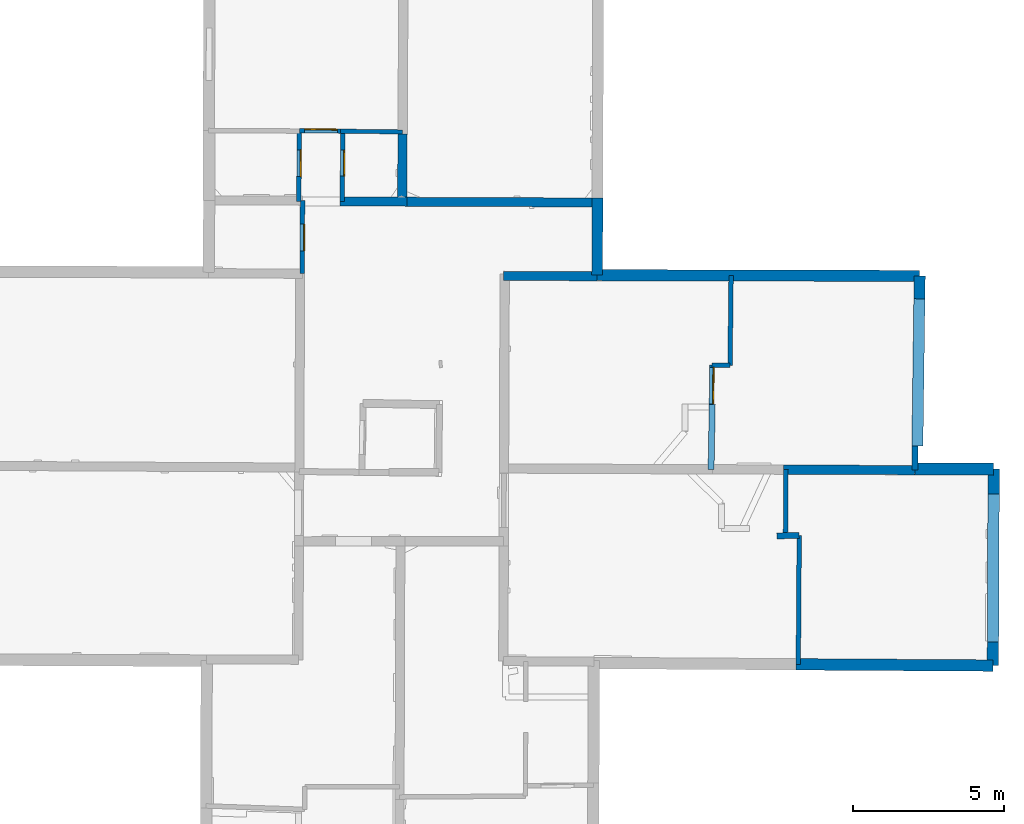
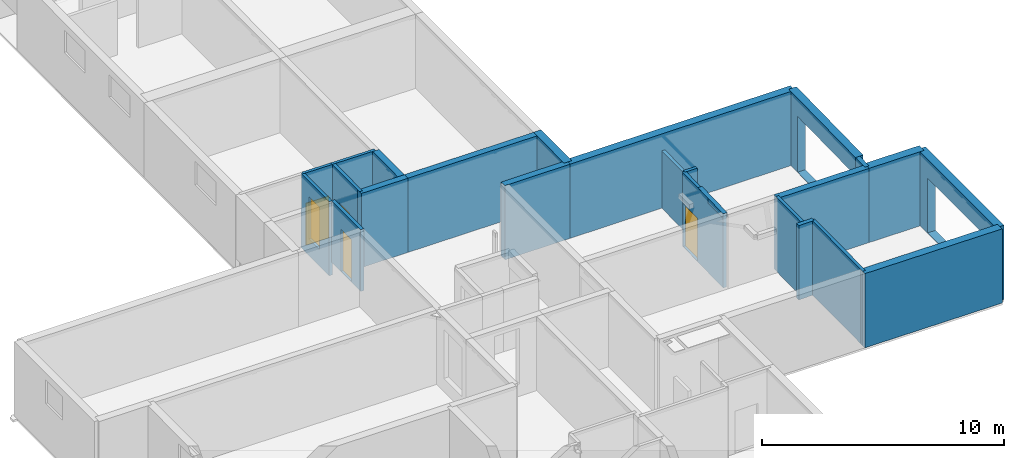
# One storey, part 4 of 12: 24 walls, 5 doors, 7 openings.
"""IFC2X3 building model written with IfcOpenShell, lengths in metres."""

from ifc_helpers import new_model, entity, si_unit, converted_unit, derived_unit, direction, frame, frame_2d, origin, origin_2d_with_axis, place, context, subcontext, project, spatial, polyline, rectangle, outline, extrude, source, transform, mapped, material, layer, layer_set, layer_usage, type_object, type_shapes, element, fill, save


model = new_model("IFC2X3")

# Units and contexts
model_context = context("Model", 3, precision=1e-05, world=origin(), true_north=direction((0.0, 1.0)))
body_context = subcontext(model_context, "Body", "Model", "MODEL_VIEW")
ifc_project = project(units=[si_unit("LENGTHUNIT", "METRE"), si_unit("AREAUNIT", "SQUARE_METRE"), si_unit("VOLUMEUNIT", "CUBIC_METRE"), converted_unit("PLANEANGLEUNIT", "DEGREE", entity("IfcRatioMeasure", 0.0174532925199433), si_unit("PLANEANGLEUNIT", "RADIAN"), dimensions=[0, 0, 0, 0, 0, 0, 0]), si_unit("MASSUNIT", "GRAM", prefix="KILO"), derived_unit("MASSDENSITYUNIT", [(si_unit("MASSUNIT", "GRAM", prefix="KILO"), 1), (si_unit("LENGTHUNIT", "METRE"), -3)]), derived_unit("MOMENTOFINERTIAUNIT", [(si_unit("LENGTHUNIT", "METRE"), 4)]), si_unit("TIMEUNIT", "SECOND"), si_unit("FREQUENCYUNIT", "HERTZ"), si_unit("THERMODYNAMICTEMPERATUREUNIT", "DEGREE_CELSIUS"), derived_unit("THERMALTRANSMITTANCEUNIT", [(si_unit("MASSUNIT", "GRAM", prefix="KILO"), 1), (si_unit("THERMODYNAMICTEMPERATUREUNIT", "KELVIN"), -1), (si_unit("TIMEUNIT", "SECOND"), -3)]), derived_unit("VOLUMETRICFLOWRATEUNIT", [(si_unit("LENGTHUNIT", "METRE"), 3), (si_unit("TIMEUNIT", "SECOND"), -1)]), si_unit("ELECTRICCURRENTUNIT", "AMPERE"), si_unit("ELECTRICVOLTAGEUNIT", "VOLT"), si_unit("POWERUNIT", "WATT"), si_unit("FORCEUNIT", "NEWTON", prefix="KILO"), si_unit("ILLUMINANCEUNIT", "LUX"), si_unit("LUMINOUSFLUXUNIT", "LUMEN"), si_unit("LUMINOUSINTENSITYUNIT", "CANDELA"), derived_unit("USERDEFINED", [(si_unit("MASSUNIT", "GRAM", prefix="KILO"), -1), (si_unit("LENGTHUNIT", "METRE"), -2), (si_unit("TIMEUNIT", "SECOND"), 3), (si_unit("LUMINOUSFLUXUNIT", "LUMEN"), 1)]), derived_unit("LINEARVELOCITYUNIT", [(si_unit("LENGTHUNIT", "METRE"), 1), (si_unit("TIMEUNIT", "SECOND"), -1)]), si_unit("PRESSUREUNIT", "PASCAL"), derived_unit("USERDEFINED", [(si_unit("LENGTHUNIT", "METRE"), -2), (si_unit("MASSUNIT", "GRAM", prefix="KILO"), 1), (si_unit("TIMEUNIT", "SECOND"), -2)]), derived_unit("LINEARFORCEUNIT", [(si_unit("MASSUNIT", "GRAM", prefix="KILO"), 1), (si_unit("LENGTHUNIT", "METRE"), 1), (si_unit("TIMEUNIT", "SECOND"), -2), (si_unit("LENGTHUNIT", "METRE"), -1)]), derived_unit("PLANARFORCEUNIT", [(si_unit("MASSUNIT", "GRAM", prefix="KILO"), 1), (si_unit("LENGTHUNIT", "METRE"), 1), (si_unit("TIMEUNIT", "SECOND"), -2), (si_unit("LENGTHUNIT", "METRE"), -2)])], contexts=[model_context])

# Site, building, storey
placement_1 = place(None, origin())
site = spatial("IfcSite", under=ifc_project, at=placement_1, CompositionType="ELEMENT")
building = spatial("IfcBuilding", under=site, at=placement_1, CompositionType="ELEMENT")
storey_placement = place(placement_1, frame((0.0, 0.0, -1.46125340461731)))
storey = spatial("IfcBuildingStorey", under=building, at=storey_placement, Name="Level 1", CompositionType="ELEMENT", Elevation=-1.46125340461731)

# Walls
ifc_material_1 = material(Name="Default wall")
ifc_layer_1 = layer(ifc_material_1, 0.2)
ifc_layer_set_1 = layer_set([ifc_layer_1], Name="wall_thickness_0.2000")
ifc_layer_usage_1 = layer_usage(ifc_layer_set_1, "AXIS2", "POSITIVE", -0.1)
wall_type_1 = type_object("IfcWallType", Name="wall_thickness_0.2000", PredefinedType="STANDARD", material=ifc_layer_set_1)
wall_1_placement = place(storey_placement, frame((18.6490779756454, 17.1740591295376, 0.0), z_axis=(0.0, 0.0, 1.0), x_axis=(0.999891502829233, 0.0147303282345586, 0.0)))
element("IfcWallStandardCase", 1, at=wall_1_placement, inside=storey, type_object=wall_type_1, material=ifc_layer_usage_1, Name="Wall:608", ObjectType="Wall", context=body_context, shape_type="SweptSolid", body=[
    extrude(outline(polyline([(0.744276690025487, -0.1), (0.744276690025487, 0.1), (0.0, 0.1), (0.0, -0.1), (0.744276690025487, -0.1)])), origin(), (0.0, 0.0, 1.0), 3.74198617935181),
])
wall_2_placement = place(storey_placement, frame((23.2358447544177, 20.1531341213829, 0.0), z_axis=(0.0, 0.0, 1.0), x_axis=(-0.0126945433330581, -0.999919421038298, 0.0)))
element("IfcWallStandardCase", 2, at=wall_2_placement, inside=storey, type_object=wall_type_1, material=ifc_layer_usage_1, Name="Wall:653", ObjectType="Wall", context=body_context, shape_type="SweptSolid", body=[
    extrude(outline(polyline([(0.799928272697267, -0.1), (0.799928272697267, 0.1), (0.0, 0.1), (0.0, -0.1), (0.799928272697267, -0.1)])), origin(), (0.0, 0.0, 1.0), 3.74198617935181),
])
placement_2 = place(placement_1, frame((0.0, 0.0, 2.04199981689453)))
wall_3_placement = place(placement_2, frame((16.4694131691114, 19.3806354082784, 0.0), z_axis=(0.0, 0.0, 1.0), x_axis=(0.0179968916085182, 0.999838042831153, 0.0)))
element("IfcWallStandardCase", 3, at=wall_3_placement, inside=storey, type_object=wall_type_1, material=ifc_layer_usage_1, Name="Wall:681", ObjectType="Wall", context=body_context, shape_type="SweptSolid", body=[
    extrude(outline(polyline([(2.15260273405872, -0.1), (2.15260273405872, 0.1), (0.0, 0.1), (0.0, -0.1), (2.15260273405872, -0.1)])), origin(), (0.0, 0.0, 1.0), 0.238732957839966),
])
ifc_layer_2 = layer(ifc_material_1, 0.379999995231628)
ifc_layer_set_2 = layer_set([ifc_layer_2], Name="wall_thickness_0.3800")
ifc_layer_usage_2 = layer_usage(ifc_layer_set_2, "AXIS2", "POSITIVE", -0.189999997615814)
wall_type_2 = type_object("IfcWallType", Name="wall_thickness_0.3800", PredefinedType="STANDARD", material=ifc_layer_set_2)
wall_4_placement = place(storey_placement, frame((19.2877350168227, 12.911915257359, 0.0), z_axis=(0.0, 0.0, 1.0), x_axis=(0.999979999783227, -0.00632455797173892, 0.0)))
element("IfcWallStandardCase", 4, at=wall_4_placement, inside=storey, type_object=wall_type_2, material=ifc_layer_usage_2, Name="Wall:521", ObjectType="Wall", context=body_context, shape_type="SweptSolid", body=[
    extrude(outline(polyline([(6.53007216169667, -0.189999997615814), (6.53007216169667, 0.189999997615814), (0.0, 0.189999997615814), (0.0, -0.189999997615814), (6.53007216169667, -0.189999997615814)])), origin(), (0.0, 0.0, 1.0), 3.74198617935181),
])

# Wall, opening
wall_5_placement = place(storey_placement, frame((25.8438703285536, 19.3839390076992, 0.0), z_axis=(0.0, 0.0, 1.0), x_axis=(-0.00402180381335679, -0.99999191251434, 0.0)))
wall_5 = element("IfcWallStandardCase", 5, at=wall_5_placement, inside=storey, type_object=wall_type_2, material=ifc_layer_usage_2, Name="Wall:671", ObjectType="Wall", context=body_context, shape_type="SweptSolid", body=[
    extrude(outline(polyline([(6.51337741439527, -0.189999997615814), (6.51337741439527, 0.189999997615814), (0.0, 0.189999997615814), (0.0, -0.189999997615814), (6.51337741439527, -0.189999997615814)])), origin(), (0.0, 0.0, 1.0), 3.74198617935181),
])
opening_1_placement = place(wall_5_placement, frame((0.823121023784291, -0.189999997615814, 0.0262539386749268)))
element("IfcOpeningElement", 6, at=opening_1_placement, cuts=wall_5, Name="Opening : 4905 x 2750 : 429", ObjectType="Opening", context=body_context, shape_type="SweptSolid", body=[
    extrude(rectangle(XDim=4.905, YDim=2.75, at=frame_2d((1.375, 2.4525), x_axis=(0.0, 1.0))), frame((0.0, 0.0, 0.0), z_axis=(0.0, 1.0, 0.0), x_axis=(0.0, 0.0, 1.0)), (0.0, 0.0, 1.0), 0.379999995231628),
])

# Wall
ifc_layer_3 = layer(ifc_material_1, 0.370000004768372)
ifc_layer_set_3 = layer_set([ifc_layer_3], Name="wall_thickness_0.3700")
ifc_layer_usage_3 = layer_usage(ifc_layer_set_3, "AXIS2", "POSITIVE", -0.185000002384186)
wall_type_3 = type_object("IfcWallType", Name="wall_thickness_0.3700", PredefinedType="STANDARD", material=ifc_layer_set_3)
wall_6_placement = place(storey_placement, frame((12.6910763943773, 25.8209457186515, 0.0), z_axis=(0.0, 0.0, 1.0), x_axis=(0.999997215283087, -0.00235996315037195, 0.0)))
element("IfcWallStandardCase", 7, at=wall_6_placement, inside=storey, type_object=wall_type_3, material=ifc_layer_usage_3, Name="Wall:637", ObjectType="Wall", context=body_context, shape_type="SweptSolid", body=[
    extrude(outline(polyline([(10.6990997707707, -0.185000002384186), (10.6990997707707, 0.185000002384186), (0.0, 0.185000002384186), (0.0, -0.185000002384186), (10.6990997707707, -0.185000002384186)])), origin(), (0.0, 0.0, 1.0), 3.74198617935181),
])

# Wall, opening
wall_7_placement = place(storey_placement, frame((23.3901475915974, 25.7956942491821, 0.0), z_axis=(0.0, 0.0, 1.0), x_axis=(-0.0136085227679634, -0.999907399766635, 0.0)))
wall_7 = element("IfcWallStandardCase", 8, at=wall_7_placement, inside=storey, type_object=wall_type_3, material=ifc_layer_usage_3, Name="Wall:654", ObjectType="Wall", context=body_context, shape_type="SweptSolid", body=[
    extrude(outline(polyline([(5.64389802300253, -0.185000002384186), (5.64389802300253, 0.185000002384186), (0.0, 0.185000002384186), (0.0, -0.185000002384186), (5.64389802300253, -0.185000002384186)])), origin(), (0.0, 0.0, 1.0), 3.74198617935181),
])
opening_2_placement = place(wall_7_placement, frame((0.758727725921438, -0.185000002384186, 0.0242540836334229)))
element("IfcOpeningElement", 9, at=opening_2_placement, cuts=wall_7, Name="Opening : 4930 x 2800 : 426", ObjectType="Opening", context=body_context, shape_type="SweptSolid", body=[
    extrude(rectangle(XDim=4.93, YDim=2.8, at=frame_2d((1.4, 2.465), x_axis=(0.0, 1.0))), frame((0.0, 0.0, 0.0), z_axis=(0.0, 1.0, 0.0), x_axis=(0.0, 0.0, 1.0)), (0.0, 0.0, 1.0), 0.370000004768372),
])

# Walls
ifc_layer_4 = layer(ifc_material_1, 0.360000014305115)
ifc_layer_set_4 = layer_set([ifc_layer_4], Name="wall_thickness_0.3600")
ifc_layer_usage_4 = layer_usage(ifc_layer_set_4, "AXIS2", "POSITIVE", -0.180000007152557)
wall_type_4 = type_object("IfcWallType", Name="wall_thickness_0.3600", PredefinedType="STANDARD", material=ifc_layer_set_4)
wall_8_placement = place(storey_placement, frame((12.7004056599244, 28.3816105624577, 0.0), z_axis=(0.0, 0.0, 1.0), x_axis=(-0.00364346981659502, -0.99999336254182, 0.0)))
element("IfcWallStandardCase", 10, at=wall_8_placement, inside=storey, type_object=wall_type_4, material=ifc_layer_usage_4, Name="Wall:590", ObjectType="Wall", context=body_context, shape_type="SweptSolid", body=[
    extrude(outline(polyline([(2.56068975648094, -0.180000007152557), (2.56068975648094, 0.180000007152557), (0.0, 0.180000007152557), (0.0, -0.180000007152557), (2.56068975648094, -0.180000007152557)])), origin(), (0.0, 0.0, 1.0), 3.74198617935181),
])
ifc_layer_5 = layer(ifc_material_1, 0.150000005960464)
ifc_layer_set_5 = layer_set([ifc_layer_5], Name="wall_thickness_0.1500")
ifc_layer_usage_5 = layer_usage(ifc_layer_set_5, "AXIS2", "POSITIVE", -0.0750000029802322)
wall_type_5 = type_object("IfcWallType", Name="wall_thickness_0.1500", PredefinedType="STANDARD", material=ifc_layer_set_5)
wall_9_placement = place(storey_placement, frame((19.3932735397804, 17.1850223850124, 0.0), z_axis=(0.0, 0.0, 1.0), x_axis=(-0.00714615589658702, -0.999974465901956, 0.0)))
element("IfcWallStandardCase", 11, at=wall_9_placement, inside=storey, type_object=wall_type_5, material=ifc_layer_usage_5, Name="Wall:516", ObjectType="Wall", context=body_context, shape_type="SweptSolid", body=[
    extrude(outline(polyline([(4.27369158335599, -0.0750000029802322), (4.27369158335599, 0.0750000029802322), (0.0, 0.0750000029802322), (0.0, -0.0750000029802322), (4.27369158335599, -0.0750000029802322)])), origin(), (0.0, 0.0, 1.0), 3.74198617935181),
])

# Wall, opening, door
wall_10_placement = place(storey_placement, frame((2.81240836452658, 30.6139363765308, 0.0), z_axis=(0.0, 0.0, 1.0), x_axis=(-0.00733618955812565, -0.999973089799304, 0.0)))
wall_10 = element("IfcWallStandardCase", 12, at=wall_10_placement, inside=storey, type_object=wall_type_5, material=ifc_layer_usage_5, Name="Wall:560", ObjectType="Wall", context=body_context, shape_type="SweptSolid", body=[
    extrude(outline(polyline([(2.34340298148849, -0.0750000029802322), (2.34340298148849, 0.0750000029802322), (0.0, 0.0750000029802322), (0.0, -0.0750000029802322), (2.34340298148849, -0.0750000029802322)])), origin(), (0.0, 0.0, 1.0), 3.74198617935181),
])
opening_3_placement = place(wall_10_placement, frame((0.636959059717189, -0.0750000029802322, 0.834253430366516)))
opening_3 = element("IfcOpeningElement", 13, at=opening_3_placement, cuts=wall_10, Name="Opening : 890 x 2140 : 411", ObjectType="Opening", context=body_context, shape_type="SweptSolid", body=[
    extrude(rectangle(XDim=0.89, YDim=2.14, at=frame_2d((1.07, 0.445), x_axis=(0.0, 1.0))), frame((0.0, 0.0, 0.0), z_axis=(0.0, 1.0, 0.0), x_axis=(0.0, 0.0, 1.0)), (0.0, 0.0, 1.0), 0.150000005960464),
])
ifc_material_2 = material(Name="Door Panel")
door_style_1 = type_object("IfcDoorStyle", Name="Door : 890 x 2140mm", ConstructionType="NOTDEFINED", OperationType="SINGLE_SWING_RIGHT", ParameterTakesPrecedence=False, Sizeable=False, material=ifc_material_2)
shared_shape_1 = source(origin(), body_context, "Body", "SweptSolid", [
    extrude(rectangle(XDim=0.0375000014901161, YDim=0.89, at=origin_2d_with_axis()), frame((0.445, 0.131250005215406, 0.0), z_axis=(0.0, 0.0, 1.0), x_axis=(0.0, 1.0, 0.0)), (0.0, 0.0, 1.0), 2.14),
])
type_shapes(door_style_1, [shared_shape_1])
door_1_placement = place(opening_3_placement, origin())
door_1 = element("IfcDoor", 14, at=door_1_placement, inside=storey, type_object=door_style_1, Name="Door : 890 x 2140mm : 76", ObjectType="Door : 890 x 2140mm", OverallHeight=2.14, OverallWidth=0.89, context=body_context, shape_type="MappedRepresentation", body=[
    mapped(shared_shape_1, transform((0.0, 0.0, 0.0), scale=1.0)),
])
fill(opening_3, door_1)

wall_11_placement = place(storey_placement, frame((16.5005587395405, 22.8404019214953, 0.0), z_axis=(0.0, 0.0, 1.0), x_axis=(-0.0151989176451258, -0.999884489779903, 0.0)))
wall_11 = element("IfcWallStandardCase", 15, at=wall_11_placement, inside=storey, type_object=wall_type_5, material=ifc_layer_usage_5, Name="Wall:580", ObjectType="Wall", context=body_context, shape_type="SweptSolid", body=[
    extrude(outline(polyline([(3.46007641674216, -0.0750000029802322), (3.46007641674216, 0.0750000029802322), (0.0, 0.0750000029802322), (0.0, -0.0750000029802322), (3.46007641674216, -0.0750000029802322)])), origin(), (0.0, 0.0, 1.0), 3.74198617935181),
])
opening_4_placement = place(wall_11_placement, frame((0.0792003469104175, -0.0750000029802322, 0.0232536792755127)))
opening_4 = element("IfcOpeningElement", 16, at=opening_4_placement, cuts=wall_11, Name="Opening : 1210 x 2160 : 415", ObjectType="Opening", context=body_context, shape_type="SweptSolid", body=[
    extrude(rectangle(XDim=1.21, YDim=2.16, at=frame_2d((1.08, 0.605), x_axis=(0.0, 1.0))), frame((0.0, 0.0, 0.0), z_axis=(0.0, 1.0, 0.0), x_axis=(0.0, 0.0, 1.0)), (0.0, 0.0, 1.0), 0.150000005960464),
])
door_style_2 = type_object("IfcDoorStyle", Name="Door : 1210 x 2160mm", ConstructionType="NOTDEFINED", OperationType="SINGLE_SWING_RIGHT", ParameterTakesPrecedence=False, Sizeable=False, material=ifc_material_2)
shared_shape_2 = source(origin(), body_context, "Body", "SweptSolid", [
    extrude(rectangle(XDim=0.0375000014901161, YDim=1.21, at=origin_2d_with_axis()), frame((0.605, 0.131250005215406, 0.0), z_axis=(0.0, 0.0, 1.0), x_axis=(0.0, 1.0, 0.0)), (0.0, 0.0, 1.0), 2.16),
])
type_shapes(door_style_2, [shared_shape_2])
door_2_placement = place(opening_4_placement, origin())
door_2 = element("IfcDoor", 17, at=door_2_placement, inside=storey, type_object=door_style_2, Name="Door : 1210 x 2160mm : 77", ObjectType="Door : 1210 x 2160mm", OverallHeight=2.16, OverallWidth=1.21, context=body_context, shape_type="MappedRepresentation", body=[
    mapped(shared_shape_2, transform((0.0, 0.0, 0.0), scale=1.0)),
])
fill(opening_4, door_2)

placement_3 = place(placement_1, frame((0.0, 0.0, -0.835000038146973)))
wall_12_placement = place(placement_3, frame((2.91802655715019, 28.2912347370215, 0.0), z_axis=(0.0, 0.0, 1.0), x_axis=(-0.00284513435591406, -0.999995952597058, 0.0)))
wall_12 = element("IfcWallStandardCase", 18, at=wall_12_placement, inside=storey, type_object=wall_type_5, material=ifc_layer_usage_5, Name="Wall:604", ObjectType="Wall", context=body_context, shape_type="SweptSolid", body=[
    extrude(outline(polyline([(2.41977145150494, -0.0750000029802322), (2.41977145150494, 0.0750000029802322), (0.0, 0.0750000029802322), (0.0, -0.0750000029802322), (2.41977145150494, -0.0750000029802322)])), origin(), (0.0, 0.0, 1.0), 3.11573281288147),
])
opening_5_placement = place(wall_12_placement, frame((0.776826192065377, -0.0750000029802322, 0.0250004529953003)))
opening_5 = element("IfcOpeningElement", 19, at=opening_5_placement, cuts=wall_12, Name="Opening : 890 x 2125 : 419", ObjectType="Opening", context=body_context, shape_type="SweptSolid", body=[
    extrude(rectangle(XDim=0.89, YDim=2.125, at=frame_2d((1.0625, 0.445), x_axis=(0.0, 1.0))), frame((0.0, 0.0, 0.0), z_axis=(0.0, 1.0, 0.0), x_axis=(0.0, 0.0, 1.0)), (0.0, 0.0, 1.0), 0.150000005960464),
])
door_style_3 = type_object("IfcDoorStyle", Name="Door : 890 x 2125mm", ConstructionType="NOTDEFINED", OperationType="SINGLE_SWING_RIGHT", ParameterTakesPrecedence=False, Sizeable=False, material=ifc_material_2)
shared_shape_3 = source(origin(), body_context, "Body", "SweptSolid", [
    extrude(rectangle(XDim=0.0375000014901161, YDim=0.89, at=origin_2d_with_axis()), frame((0.445, 0.131250005215406, 0.0), z_axis=(0.0, 0.0, 1.0), x_axis=(0.0, 1.0, 0.0)), (0.0, 0.0, 1.0), 2.125),
])
type_shapes(door_style_3, [shared_shape_3])
door_3_placement = place(opening_5_placement, origin())
door_3 = element("IfcDoor", 20, at=door_3_placement, inside=storey, type_object=door_style_3, Name="Door : 890 x 2125mm : 79", ObjectType="Door : 890 x 2125mm", OverallHeight=2.125, OverallWidth=0.89, context=body_context, shape_type="MappedRepresentation", body=[
    mapped(shared_shape_3, transform((0.0, 0.0, 0.0), scale=1.0)),
])
fill(opening_5, door_3)

# Walls
wall_13_placement = place(storey_placement, frame((18.9544588392475, 19.3705692829054, 0.0), z_axis=(0.0, 0.0, 1.0), x_axis=(-0.00808755304041783, -0.999967295208108, 0.0)))
element("IfcWallStandardCase", 21, at=wall_13_placement, inside=storey, type_object=wall_type_5, material=ifc_layer_usage_5, Name="Wall:631", ObjectType="Wall", context=body_context, shape_type="SweptSolid", body=[
    extrude(outline(polyline([(2.19234579384087, -0.0750000029802322), (2.19234579384087, 0.0750000029802322), (0.0, 0.0750000029802322), (0.0, -0.0750000029802322), (2.19234579384087, -0.0750000029802322)])), origin(), (0.0, 0.0, 1.0), 3.74198617935181),
])
wall_14_placement = place(storey_placement, frame((17.133230294602, 25.8104621652182, 0.0), z_axis=(0.0, 0.0, 1.0), x_axis=(-0.011403736082066, -0.999934975287579, 0.0)))
element("IfcWallStandardCase", 22, at=wall_14_placement, inside=storey, type_object=wall_type_5, material=ifc_layer_usage_5, Name="Wall:636", ObjectType="Wall", context=body_context, shape_type="SweptSolid", body=[
    extrude(outline(polyline([(2.97900497297976, -0.0750000029802322), (2.97900497297976, 0.0750000029802322), (0.0, 0.0750000029802322), (0.0, -0.0750000029802322), (2.97900497297976, -0.0750000029802322)])), origin(), (0.0, 0.0, 1.0), 2.89025378227234),
])

# Wall, opening, door
wall_15_placement = place(storey_placement, frame((4.25228662497294, 30.5963914696705, 0.0), z_axis=(0.0, 0.0, 1.0), x_axis=(-0.00618257879093177, -0.999980887677106, 0.0)))
wall_15 = element("IfcWallStandardCase", 23, at=wall_15_placement, inside=storey, type_object=wall_type_5, material=ifc_layer_usage_5, Name="Wall:652", ObjectType="Wall", context=body_context, shape_type="SweptSolid", body=[
    extrude(outline(polyline([(2.33151695755551, -0.0750000029802322), (2.33151695755551, 0.0750000029802322), (0.0, 0.0750000029802322), (0.0, -0.0750000029802322), (2.33151695755551, -0.0750000029802322)])), origin(), (0.0, 0.0, 1.0), 3.74198617935181),
])
opening_6_placement = place(wall_15_placement, frame((0.629404650630092, -0.0750000029802322, 0.0192539691925049)))
opening_6 = element("IfcOpeningElement", 24, at=opening_6_placement, cuts=wall_15, Name="Opening : 865 x 2135 : 425", ObjectType="Opening", context=body_context, shape_type="SweptSolid", body=[
    extrude(rectangle(XDim=0.865, YDim=2.135, at=frame_2d((1.0675, 0.4325), x_axis=(0.0, 1.0))), frame((0.0, 0.0, 0.0), z_axis=(0.0, 1.0, 0.0), x_axis=(0.0, 0.0, 1.0)), (0.0, 0.0, 1.0), 0.150000005960464),
])
door_style_4 = type_object("IfcDoorStyle", Name="Door : 865 x 2135mm", ConstructionType="NOTDEFINED", OperationType="SINGLE_SWING_RIGHT", ParameterTakesPrecedence=False, Sizeable=False, material=ifc_material_2)
shared_shape_4 = source(origin(), body_context, "Body", "SweptSolid", [
    extrude(rectangle(XDim=0.0375000014901161, YDim=0.865, at=origin_2d_with_axis()), frame((0.4325, 0.131250005215406, 0.0), z_axis=(0.0, 0.0, 1.0), x_axis=(0.0, 1.0, 0.0)), (0.0, 0.0, 1.0), 2.135),
])
type_shapes(door_style_4, [shared_shape_4])
door_4_placement = place(opening_6_placement, origin())
door_4 = element("IfcDoor", 25, at=door_4_placement, inside=storey, type_object=door_style_4, Name="Door : 865 x 2135mm : 81", ObjectType="Door : 865 x 2135mm", OverallHeight=2.135, OverallWidth=0.865, context=body_context, shape_type="MappedRepresentation", body=[
    mapped(shared_shape_4, transform((0.0, 0.0, 0.0), scale=1.0)),
])
fill(opening_6, door_4)

# Wall
ifc_layer_6 = layer(ifc_material_1, 0.400000005960464)
ifc_layer_set_6 = layer_set([ifc_layer_6], Name="wall_thickness_0.4000")
ifc_layer_usage_6 = layer_usage(ifc_layer_set_6, "AXIS2", "POSITIVE", -0.200000002980232)
wall_type_6 = type_object("IfcWallType", Name="wall_thickness_0.4000", PredefinedType="STANDARD", material=ifc_layer_set_6)
wall_16_placement = place(storey_placement, frame((23.226272022038, 19.3992007833482, 0.0), z_axis=(0.0, 0.0, 1.0), x_axis=(0.999983009977777, -0.00582921570929077, 0.0)))
element("IfcWallStandardCase", 26, at=wall_16_placement, inside=storey, type_object=wall_type_6, material=ifc_layer_usage_6, Name="Wall:656", ObjectType="Wall", context=body_context, shape_type="SweptSolid", body=[
    extrude(outline(polyline([(2.61764014637168, -0.200000002980232), (2.61764014637168, 0.200000002980232), (0.0, 0.200000002980232), (0.0, -0.200000002980232), (2.61764014637168, -0.200000002980232)])), origin(), (0.0, 0.0, 1.0), 3.74198617935181),
])

# Wall, opening, door
ifc_layer_7 = layer(ifc_material_1, 0.140000000596046)
ifc_layer_set_7 = layer_set([ifc_layer_7], Name="wall_thickness_0.1400")
ifc_layer_usage_7 = layer_usage(ifc_layer_set_7, "AXIS2", "POSITIVE", -0.0700000002980232)
wall_type_7 = type_object("IfcWallType", Name="wall_thickness_0.1400", PredefinedType="STANDARD", material=ifc_layer_set_7)
wall_17_placement = place(storey_placement, frame((2.81240750207452, 30.6139343954024, 0.0), z_axis=(0.0, 0.0, 1.0), x_axis=(0.99992577975476, -0.0121833895872523, 0.0)))
wall_17 = element("IfcWallStandardCase", 27, at=wall_17_placement, inside=storey, type_object=wall_type_7, material=ifc_layer_usage_7, Name="Wall:509", ObjectType="Wall", context=body_context, shape_type="SweptSolid", body=[
    extrude(outline(polyline([(1.36498735515218, -0.0700000002980232), (1.36498735515218, 0.0700000002980232), (0.0, 0.0700000002980232), (0.0, -0.0700000002980232), (1.36498735515218, -0.0700000002980232)])), origin(), (0.0, 0.0, 1.0), 3.74198617935181),
])
opening_7_placement = place(wall_17_placement, frame((0.177325309702382, -0.0700000002980232, 0.00925374031066895)))
opening_7 = element("IfcOpeningElement", 28, at=opening_7_placement, cuts=wall_17, Name="Opening : 1085 x 2115 : 402", ObjectType="Opening", context=body_context, shape_type="SweptSolid", body=[
    extrude(rectangle(XDim=1.085, YDim=2.115, at=frame_2d((1.0575, 0.5425), x_axis=(0.0, 1.0))), frame((0.0, 0.0, 0.0), z_axis=(0.0, 1.0, 0.0), x_axis=(0.0, 0.0, 1.0)), (0.0, 0.0, 1.0), 0.140000000596046),
])
door_style_5 = type_object("IfcDoorStyle", Name="Door : 1085 x 2115mm", ConstructionType="NOTDEFINED", OperationType="SINGLE_SWING_RIGHT", ParameterTakesPrecedence=False, Sizeable=False, material=ifc_material_2)
shared_shape_5 = source(origin(), body_context, "Body", "SweptSolid", [
    extrude(rectangle(XDim=0.0350000001490116, YDim=1.085, at=origin_2d_with_axis()), frame((0.5425, 0.122500000521541, 0.0), z_axis=(0.0, 0.0, 1.0), x_axis=(0.0, 1.0, 0.0)), (0.0, 0.0, 1.0), 2.115),
])
type_shapes(door_style_5, [shared_shape_5])
door_5_placement = place(opening_7_placement, origin())
door_5 = element("IfcDoor", 29, at=door_5_placement, inside=storey, type_object=door_style_5, Name="Door : 1085 x 2115mm : 73", ObjectType="Door : 1085 x 2115mm", OverallHeight=2.115, OverallWidth=1.085, context=body_context, shape_type="MappedRepresentation", body=[
    mapped(shared_shape_5, transform((0.0, 0.0, 0.0), scale=1.0)),
])
fill(opening_7, door_5)

# Walls
wall_18_placement = place(storey_placement, frame((4.17729354753046, 30.5973042226729, 0.0), z_axis=(0.0, 0.0, 1.0), x_axis=(0.999925766672619, -0.0121844632288493, 0.0)))
element("IfcWallStandardCase", 30, at=wall_18_placement, inside=storey, type_object=wall_type_7, material=ifc_layer_usage_7, Name="Wall:510", ObjectType="Wall", context=body_context, shape_type="SweptSolid", body=[
    extrude(outline(polyline([(2.05990203981682, -0.0700000002980232), (2.05990203981682, 0.0700000002980232), (0.0, 0.0700000002980232), (0.0, -0.0700000002980232), (2.05990203981682, -0.0700000002980232)])), origin(), (0.0, 0.0, 1.0), 3.74198617935181),
])
ifc_layer_8 = layer(ifc_material_1, 0.300000011920929)
ifc_layer_set_8 = layer_set([ifc_layer_8], Name="wall_thickness_0.3000")
ifc_layer_usage_8 = layer_usage(ifc_layer_set_8, "AXIS2", "POSITIVE", -0.150000005960464)
wall_type_8 = type_object("IfcWallType", Name="wall_thickness_0.3000", PredefinedType="STANDARD", material=ifc_layer_set_8)
wall_19_placement = place(storey_placement, frame((4.16287279792302, 28.2652118795045, 0.0), z_axis=(0.0, 0.0, 1.0), x_axis=(0.999992254384372, -0.0039358825263817, 0.0)))
element("IfcWallStandardCase", 31, at=wall_19_placement, inside=storey, type_object=wall_type_8, material=ifc_layer_usage_8, Name="Wall:511", ObjectType="Wall", context=body_context, shape_type="SweptSolid", body=[
    extrude(outline(polyline([(2.21706820176343, -0.150000005960464), (2.21706820176343, 0.150000005960464), (0.0, 0.150000005960464), (0.0, -0.150000005960464), (2.21706820176343, -0.150000005960464)])), origin(), (0.0, 0.0, 1.0), 3.74198617935181),
])
wall_20_placement = place(storey_placement, frame((6.37992382712834, 28.2564857595094, 0.0), z_axis=(0.0, 0.0, 1.0), x_axis=(0.999992254999513, -0.00393572623401671, 0.0)))
element("IfcWallStandardCase", 32, at=wall_20_placement, inside=storey, type_object=wall_type_8, material=ifc_layer_usage_8, Name="Wall:512", ObjectType="Wall", context=body_context, shape_type="SweptSolid", body=[
    extrude(outline(polyline([(6.31998570061167, -0.150000005960464), (6.31998570061167, 0.150000005960464), (0.0, 0.150000005960464), (0.0, -0.150000005960464), (6.31998570061167, -0.150000005960464)])), origin(), (0.0, 0.0, 1.0), 3.74198617935181),
])
ifc_layer_9 = layer(ifc_material_1, 0.310000002384186)
ifc_layer_set_9 = layer_set([ifc_layer_9], Name="wall_thickness_0.3100")
ifc_layer_usage_9 = layer_usage(ifc_layer_set_9, "AXIS2", "POSITIVE", -0.155000001192093)
wall_type_9 = type_object("IfcWallType", Name="wall_thickness_0.3100", PredefinedType="STANDARD", material=ifc_layer_set_9)
wall_21_placement = place(storey_placement, frame((6.23667568661416, 30.5022074085502, 0.0), z_axis=(0.0, 0.0, 1.0), x_axis=(-0.00523383685324179, -0.999986303382098, 0.0)))
element("IfcWallStandardCase", 33, at=wall_21_placement, inside=storey, type_object=wall_type_9, material=ifc_layer_usage_9, Name="Wall:553", ObjectType="Wall", context=body_context, shape_type="SweptSolid", body=[
    extrude(outline(polyline([(2.24514030893442, -0.155000001192093), (2.24514030893442, 0.155000001192093), (0.0, 0.155000001192093), (0.0, -0.155000001192093), (2.24514030893442, -0.155000001192093)])), origin(), (0.0, 0.0, 1.0), 3.74198617935181),
])
wall_22_placement = place(storey_placement, frame((18.8794597036947, 19.3708724478891, 0.0), z_axis=(0.0, 0.0, 1.0), x_axis=(0.999991798214336, -0.00405012395601487, 0.0)))
element("IfcWallStandardCase", 34, at=wall_22_placement, inside=storey, type_object=wall_type_9, material=ifc_layer_usage_9, Name="Wall:593", ObjectType="Wall", context=body_context, shape_type="SweptSolid", body=[
    extrude(outline(polyline([(4.34626710772255, -0.155000001192093), (4.34626710772255, 0.155000001192093), (0.0, 0.155000001192093), (0.0, -0.155000001192093), (4.34626710772255, -0.155000001192093)])), origin(), (0.0, 0.0, 1.0), 3.74198617935181),
])
wall_23_placement = place(storey_placement, frame((9.58324517330886, 25.7954376903966, 0.0), z_axis=(0.0, 0.0, 1.0), x_axis=(0.99999747704972, -0.00224630678981818, 0.0)))
element("IfcWallStandardCase", 35, at=wall_23_placement, inside=storey, type_object=wall_type_9, material=ifc_layer_usage_9, Name="Wall:648", ObjectType="Wall", context=body_context, shape_type="SweptSolid", body=[
    extrude(outline(polyline([(3.10772153996775, -0.155000001192093), (3.10772153996775, 0.155000001192093), (0.0, 0.155000001192093), (0.0, -0.155000001192093), (3.10772153996775, -0.155000001192093)])), origin(), (0.0, 0.0, 1.0), 3.74198617935181),
])
ifc_layer_10 = layer(ifc_material_1, 0.14849154651165)
ifc_layer_set_10 = layer_set([ifc_layer_10], Name="wall_thickness_0.1485")
ifc_layer_usage_10 = layer_usage(ifc_layer_set_10, "AXIS2", "POSITIVE", -0.074245773255825)
wall_type_10 = type_object("IfcWallType", Name="wall_thickness_0.1485", PredefinedType="STANDARD", material=ifc_layer_set_10)
wall_24_placement = place(storey_placement, frame((16.5005598068145, 22.8404045071051, 0.0), z_axis=(0.0, 0.0, 1.0), x_axis=(0.999893194828667, -0.0146150243011052, 0.0)))
element("IfcWallStandardCase", 36, at=wall_24_placement, inside=storey, type_object=wall_type_10, material=ifc_layer_usage_10, Name="Wall:630", ObjectType="Wall", context=body_context, shape_type="SweptSolid", body=[
    extrude(outline(polyline([(0.5987616131902, -0.074245773255825), (0.5987616131902, 0.074245773255825), (0.0, 0.074245773255825), (0.0, -0.074245773255825), (0.5987616131902, -0.074245773255825)])), origin(), (0.0, 0.0, 1.0), 3.74198617935181),
])

save(model, "model.ifc")
